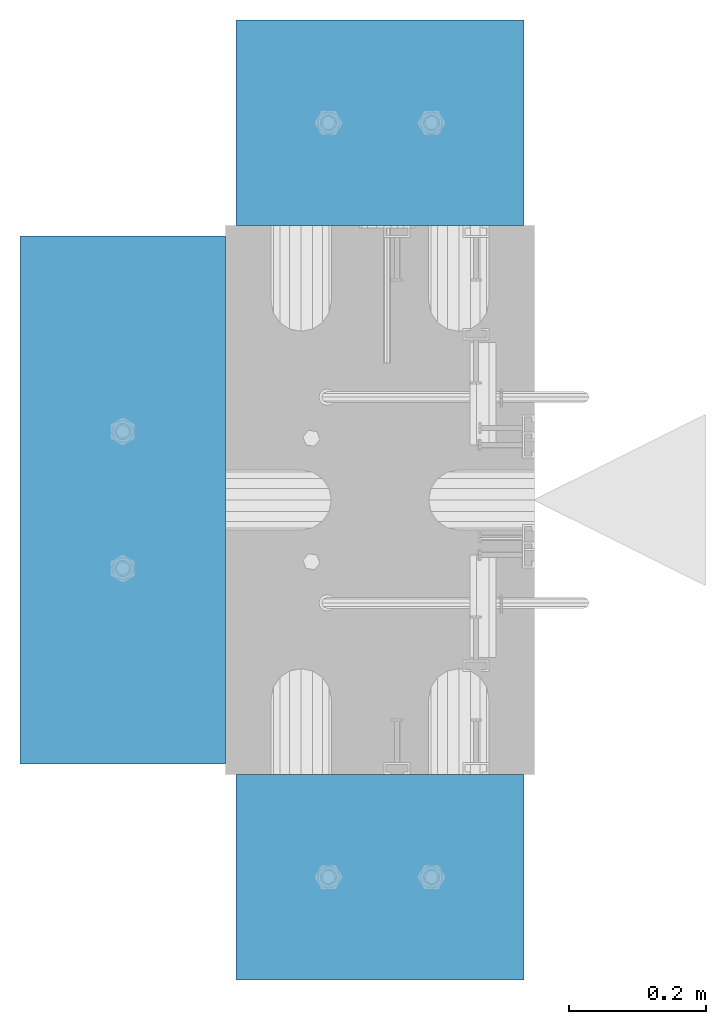
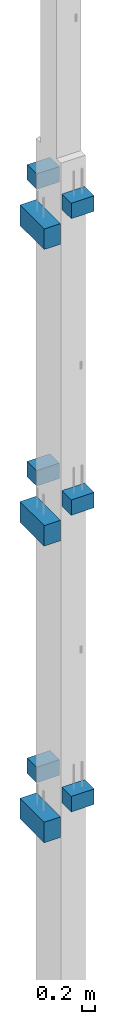
# One storey, part 18 of 41: 9 slabs, 1 element without a shape of its own.
"""IFC2X3 building model written with IfcOpenShell, lengths in millimetres."""

from ifc_helpers import new_model, si_unit, frame, origin_with_axes, place, context, subcontext, project, spatial, faceted_brep, material, type_object, element, aggregate, save


model = new_model("IFC2X3")

# Units and contexts
model_context = context("Model", 3, precision=1e-05, world=origin_with_axes())
body_context = subcontext(model_context, "Body", "Model", "MODEL_VIEW")
ifc_project = project(units=[si_unit("LENGTHUNIT", "METRE", prefix="MILLI"), si_unit("AREAUNIT", "SQUARE_METRE"), si_unit("VOLUMEUNIT", "CUBIC_METRE"), si_unit("MASSUNIT", "GRAM", prefix="KILO"), si_unit("TIMEUNIT", "SECOND"), si_unit("PLANEANGLEUNIT", "RADIAN"), si_unit("SOLIDANGLEUNIT", "STERADIAN"), si_unit("THERMODYNAMICTEMPERATUREUNIT", "DEGREE_CELSIUS"), si_unit("LUMINOUSINTENSITYUNIT", "LUMEN")], contexts=[model_context])

# Site, building, storey
site_placement = place(None, frame((-177556.685383467, -198018.589999756, 1290.0), z_axis=(0.0, 0.0, 1.0), x_axis=(0.788225611989142, -0.615386370180835, 0.0)))
site = spatial("IfcSite", under=ifc_project, at=site_placement, CompositionType="ELEMENT")
building_placement = place(site_placement, origin_with_axes())
building = spatial("IfcBuilding", under=site, at=building_placement, Name="Undefined", CompositionType="ELEMENT")
storey_placement = place(building_placement, origin_with_axes())
storey = spatial("IfcBuildingStorey", under=building, at=storey_placement, Name="Undefined", CompositionType="ELEMENT", Elevation=0.0)

# Assembly, slabs
assembly_placement = place(storey_placement, origin_with_axes())
assembly = element("IfcElementAssembly", 1, at=assembly_placement, inside=storey, AssemblyPlace="NOTDEFINED", PredefinedType="REINFORCEMENT_UNIT")
ifc_material = material(Name="CONCRETE/C50/60")
slab_type_1 = type_object("IfcSlabType", PredefinedType="NOTDEFINED")
slab_1_placement = place(assembly_placement, frame((17666.015211748, 265901.046335652, 5650.0), z_axis=(0.0, 0.0, -1.0), x_axis=(0.615386370178831, -0.788225611990706, 0.0)))
slab_1 = element("IfcSlab", 2, at=slab_1_placement, type_object=slab_type_1, material=ifc_material, Name="CONSOLE", PredefinedType="FLOOR", context=body_context, shape_type="Brep", body=[
    faceted_brep([(2.97441147267818e-07, -209.999999783293, 0.0), (2.97441147267818e-07, -209.999999783293, 300.0), (2.99507519230247e-07, 210.000000216387, 300.0), (2.99507519230247e-07, 210.000000216387, 0.0), (300.000000297325, -209.99999978402, 300.0), (300.000000299391, 210.000000215659, 300.0), (300.000000297325, -209.99999978402, 0.0), (300.000000299391, 210.000000215659, 0.0)], [[[0, 1, 2, 3]], [[1, 4, 5, 2]], [[4, 6, 7, 5]], [[6, 0, 3, 7]], [[5, 7, 3, 2]], [[6, 4, 1, 0]]]),
])
slab_2_placement = place(assembly_placement, frame((17666.0152117478, 265901.046335651, 17170.0), z_axis=(0.0, 0.0, -1.0), x_axis=(0.615386370178831, -0.788225611990706, 0.0)))
slab_2 = element("IfcSlab", 3, at=slab_2_placement, type_object=slab_type_1, material=ifc_material, Name="CONSOLE", PredefinedType="FLOOR", context=body_context, shape_type="Brep", body=[
    faceted_brep([(2.97441147267818e-07, -209.999999783293, 0.0), (2.97441147267818e-07, -209.999999783293, 300.0), (2.99507519230247e-07, 210.000000216387, 300.0), (2.99507519230247e-07, 210.000000216387, 0.0), (300.000000297325, -209.99999978402, 300.0), (300.000000299391, 210.000000215659, 300.0), (300.000000297325, -209.99999978402, 0.0), (300.000000299391, 210.000000215659, 0.0)], [[[0, 1, 2, 3]], [[1, 4, 5, 2]], [[4, 6, 7, 5]], [[6, 0, 3, 7]], [[5, 7, 3, 2]], [[6, 4, 1, 0]]]),
])
slab_3_placement = place(assembly_placement, frame((18527.5561299914, 264797.530478861, 11510.0), z_axis=(0.0, 0.0, -1.0), x_axis=(-0.615386219627735, 0.788225729529483, 0.0)))
slab_3 = element("IfcSlab", 4, at=slab_3_placement, type_object=slab_type_1, material=ifc_material, Name="CONSOLE", PredefinedType="FLOOR", context=body_context, shape_type="Brep", body=[
    faceted_brep([(2.97441147267818e-07, -209.999999783293, 0.0), (2.97441147267818e-07, -209.999999783293, 300.0), (2.99507519230247e-07, 210.000000216387, 300.0), (2.99507519230247e-07, 210.000000216387, 0.0), (300.000000297325, -209.99999978402, 300.0), (300.000000299391, 210.000000215659, 300.0), (300.000000297325, -209.99999978402, 0.0), (300.000000299391, 210.000000215659, 0.0)], [[[0, 1, 2, 3]], [[1, 4, 5, 2]], [[4, 6, 7, 5]], [[6, 0, 3, 7]], [[5, 7, 3, 2]], [[6, 4, 1, 0]]]),
])
slab_4_placement = place(assembly_placement, frame((18527.5561299914, 264797.530478861, 17270.0), z_axis=(0.0, 0.0, -1.0), x_axis=(-0.615386219627735, 0.788225729529483, 0.0)))
slab_4 = element("IfcSlab", 5, at=slab_4_placement, type_object=slab_type_1, material=ifc_material, Name="CONSOLE", PredefinedType="FLOOR", context=body_context, shape_type="Brep", body=[
    faceted_brep([(2.97441147267818e-07, -209.999999783293, 0.0), (2.97441147267818e-07, -209.999999783293, 300.0), (2.99507519230247e-07, 210.000000216387, 300.0), (2.99507519230247e-07, 210.000000216387, 0.0), (300.000000297325, -209.99999978402, 300.0), (300.000000299391, 210.000000215659, 300.0), (300.000000297325, -209.99999978402, 0.0), (300.000000299391, 210.000000215659, 0.0)], [[[0, 1, 2, 3]], [[1, 4, 5, 2]], [[4, 6, 7, 5]], [[6, 0, 3, 7]], [[5, 7, 3, 2]], [[6, 4, 1, 0]]]),
])
slab_5_placement = place(assembly_placement, frame((17666.015211748, 265901.046335652, 11410.0), z_axis=(0.0, 0.0, -1.0), x_axis=(0.615386370178831, -0.788225611990706, 0.0)))
slab_5 = element("IfcSlab", 6, at=slab_5_placement, type_object=slab_type_1, material=ifc_material, Name="CONSOLE", PredefinedType="FLOOR", context=body_context, shape_type="Brep", body=[
    faceted_brep([(2.97441147267818e-07, -209.999999783293, 0.0), (2.97441147267818e-07, -209.999999783293, 300.0), (2.99507519230247e-07, 210.000000216387, 300.0), (2.99507519230247e-07, 210.000000216387, 0.0), (300.000000297325, -209.99999978402, 300.0), (300.000000299391, 210.000000215659, 300.0), (300.000000297325, -209.99999978402, 0.0), (300.000000299391, 210.000000215659, 0.0)], [[[0, 1, 2, 3]], [[1, 4, 5, 2]], [[4, 6, 7, 5]], [[6, 0, 3, 7]], [[5, 7, 3, 2]], [[6, 4, 1, 0]]]),
])
slab_6_placement = place(assembly_placement, frame((18527.5561299915, 264797.530478861, 5749.99999999999), z_axis=(0.0, 0.0, -1.0), x_axis=(-0.615386219627735, 0.788225729529483, 0.0)))
slab_6 = element("IfcSlab", 7, at=slab_6_placement, type_object=slab_type_1, material=ifc_material, Name="CONSOLE", PredefinedType="FLOOR", context=body_context, shape_type="Brep", body=[
    faceted_brep([(2.97441147267818e-07, -209.999999783293, 0.0), (2.97441147267818e-07, -209.999999783293, 300.0), (2.99507519230247e-07, 210.000000216387, 300.0), (2.99507519230247e-07, 210.000000216387, 0.0), (300.000000297325, -209.99999978402, 300.0), (300.000000299391, 210.000000215659, 300.0), (300.000000297325, -209.99999978402, 0.0), (300.000000299391, 210.000000215659, 0.0)], [[[0, 1, 2, 3]], [[1, 4, 5, 2]], [[4, 6, 7, 5]], [[6, 0, 3, 7]], [[5, 7, 3, 2]], [[6, 4, 1, 0]]]),
])
slab_type_2 = type_object("IfcSlabType", PredefinedType="NOTDEFINED")
slab_7_placement = place(assembly_placement, frame((17682.9672245762, 265026.210562913, 10930.0), z_axis=(0.0, 0.0, -1.0), x_axis=(0.788225729527905, 0.615386219629756, 9.99999974740041e-10)))
slab_7 = element("IfcSlab", 8, at=slab_7_placement, type_object=slab_type_2, material=ifc_material, Name="CONSOLE", PredefinedType="FLOOR", context=body_context, shape_type="Brep", body=[
    faceted_brep([(-2.13651219382882e-07, -384.999999702006, 0.0), (-2.13651219382882e-07, -384.999999702006, 400.0), (-2.17580236494541e-07, 385.000000297674, 400.0), (-2.17580236494541e-07, 385.000000297674, 0.0), (299.999999786145, -384.999999701249, 400.0), (299.999999782216, 385.000000298431, 400.0), (299.999999786145, -384.999999701249, 0.0), (299.999999782216, 385.000000298431, 0.0)], [[[0, 1, 2, 3]], [[1, 4, 5, 2]], [[4, 6, 7, 5]], [[6, 0, 3, 7]], [[5, 7, 3, 2]], [[6, 4, 1, 0]]]),
])
slab_8_placement = place(assembly_placement, frame((17682.9672245762, 265026.210562913, 16690.0), z_axis=(0.0, 0.0, -1.0), x_axis=(0.788225729527905, 0.615386219629756, 9.99999974740041e-10)))
slab_8 = element("IfcSlab", 9, at=slab_8_placement, type_object=slab_type_2, material=ifc_material, Name="CONSOLE", PredefinedType="FLOOR", context=body_context, shape_type="Brep", body=[
    faceted_brep([(-2.13651219382882e-07, -384.999999702006, 0.0), (-2.13651219382882e-07, -384.999999702006, 400.0), (-2.17580236494541e-07, 385.000000297674, 400.0), (-2.17580236494541e-07, 385.000000297674, 0.0), (299.999999786145, -384.999999701249, 400.0), (299.999999782216, 385.000000298431, 400.0), (299.999999786145, -384.999999701249, 0.0), (299.999999782216, 385.000000298431, 0.0)], [[[0, 1, 2, 3]], [[1, 4, 5, 2]], [[4, 6, 7, 5]], [[6, 0, 3, 7]], [[5, 7, 3, 2]], [[6, 4, 1, 0]]]),
])
slab_9_placement = place(assembly_placement, frame((17682.9672245762, 265026.210562913, 5169.99999999999), z_axis=(0.0, 0.0, -1.0), x_axis=(0.788225729527905, 0.615386219629756, 9.99999974740041e-10)))
slab_9 = element("IfcSlab", 10, at=slab_9_placement, type_object=slab_type_2, material=ifc_material, Name="CONSOLE", PredefinedType="FLOOR", context=body_context, shape_type="Brep", body=[
    faceted_brep([(-2.13651219382882e-07, -384.999999702006, 0.0), (-2.13651219382882e-07, -384.999999702006, 400.0), (-2.17580236494541e-07, 385.000000297674, 400.0), (-2.17580236494541e-07, 385.000000297674, 0.0), (299.999999786145, -384.999999701249, 400.0), (299.999999782216, 385.000000298431, 400.0), (299.999999786145, -384.999999701249, 0.0), (299.999999782216, 385.000000298431, 0.0)], [[[0, 1, 2, 3]], [[1, 4, 5, 2]], [[4, 6, 7, 5]], [[6, 0, 3, 7]], [[5, 7, 3, 2]], [[6, 4, 1, 0]]]),
])
aggregate(assembly, [slab_1, slab_2, slab_7, slab_3, slab_4, slab_8, slab_9, slab_5, slab_6])

save(model, "model.ifc")
